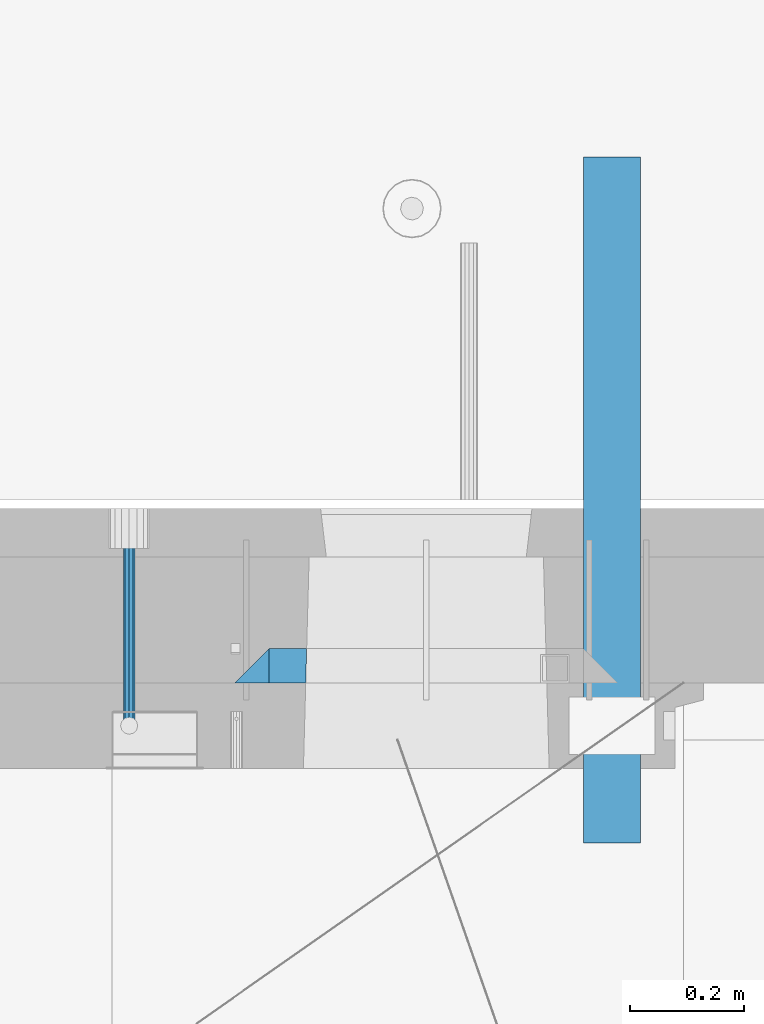
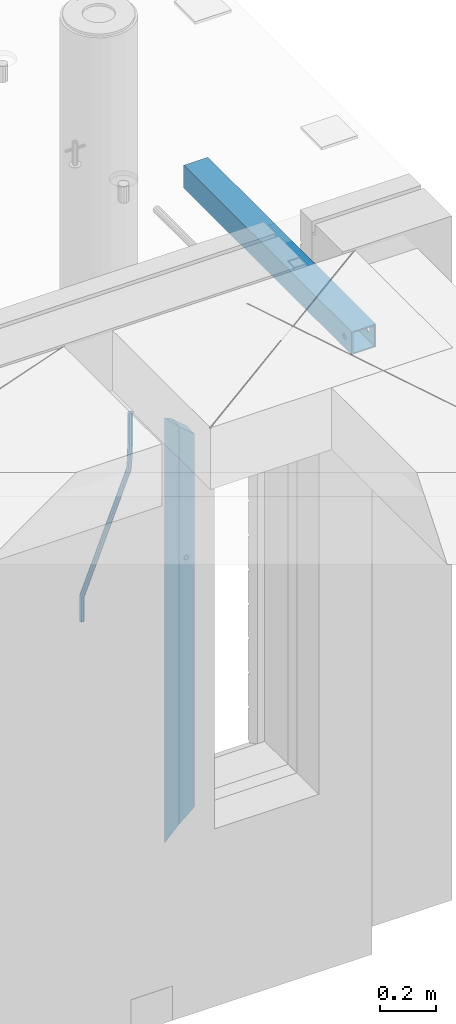
# One storey, part 114 of 309: 4 beams, 3 elements without a shape of their own.
"""IFC2X3 building model written with IfcOpenShell, lengths in millimetres."""

from ifc_helpers import new_model, si_unit, frame, origin_with_axes, place, context, subcontext, project, spatial, faceted_brep, material, type_object, element, aggregate, save


model = new_model("IFC2X3")

# Units and contexts
model_context = context("Model", 3, precision=1e-05, world=origin_with_axes())
body_context = subcontext(model_context, "Body", "Model", "MODEL_VIEW")
ifc_project = project(units=[si_unit("LENGTHUNIT", "METRE", prefix="MILLI"), si_unit("AREAUNIT", "SQUARE_METRE"), si_unit("VOLUMEUNIT", "CUBIC_METRE"), si_unit("MASSUNIT", "GRAM", prefix="KILO"), si_unit("TIMEUNIT", "SECOND"), si_unit("PLANEANGLEUNIT", "RADIAN"), si_unit("SOLIDANGLEUNIT", "STERADIAN"), si_unit("THERMODYNAMICTEMPERATUREUNIT", "DEGREE_CELSIUS"), si_unit("LUMINOUSINTENSITYUNIT", "LUMEN")], contexts=[model_context])

# Site, building, storey
site_placement = place(None, origin_with_axes())
site = spatial("IfcSite", under=ifc_project, at=site_placement, CompositionType="ELEMENT")
building_placement = place(site_placement, origin_with_axes())
building = spatial("IfcBuilding", under=site, at=building_placement, CompositionType="ELEMENT")
storey_placement = place(building_placement, origin_with_axes())
storey = spatial("IfcBuildingStorey", under=building, at=storey_placement, Name="7", CompositionType="ELEMENT", Elevation=0.0)

# Assembly, beam
assembly_1_placement = place(storey_placement, origin_with_axes())
assembly_1 = element("IfcElementAssembly", 1, at=assembly_1_placement, inside=storey, AssemblyPlace="NOTDEFINED", PredefinedType="REINFORCEMENT_UNIT")
ifc_material_1 = material()
beam_type_1 = type_object("IfcBeamType", Name="D20", PredefinedType="NOTDEFINED")
beam_1_placement = place(assembly_1_placement, frame((33890.0000001015, 20504.9951872346, 102407.5), z_axis=(0.000415599999849905, 0.999999913638203, 4.76000000899737e-07), x_axis=(0.0, 0.0, -1.0)))
beam_1 = element("IfcBeam", 2, at=beam_1_placement, type_object=beam_type_1, material=ifc_material_1, Name="JM20", ObjectType="D20", context=body_context, shape_type="Brep", body=[
    faceted_brep([(-0.00060564729210455, -9.99999998165731, 0.0), (-0.000428079845733009, -7.07106779890455, -7.07106781186667), (119.575515501536, -7.07830994756296, -7.07106481604933), (119.575337932896, -10.0072421307195, -3.43332612828817e-06), (0.0, 0.0, -10.0), (119.575943836026, -0.00724214867295814, -9.99999700418266), (0.00042843479604926, 7.07106779888636, -7.07106781186303), (119.57637202373, 7.06382565022977, -7.07106481604933), (0.00060564729210455, 9.99999998166459, 3.63797880709171e-12), (119.576549238118, 9.99275783300072, 2.99581552098971e-06), (0.000428079845733009, 7.07106779890819, 7.07106781186667), (119.576371669405, 7.06382565024978, 7.07107080768037), (0.0, 0.0, 10.0), (119.57594333493, -0.00724214864203532, 10.0000029958155), (-0.000428434810601175, -7.07106779888272, 7.07106781186667), (119.575515147211, -7.07830994754295, 7.07107080768037), (123.00654325854, -7.07836650239551, -6.96786008391246), (122.581588830741, -10.007295666459, 0.0904344953341933), (123.182419066041, -0.00729994480025198, -9.89151006310021), (123.006190977103, 7.06376911688858, -6.96788735351402), (122.581091016109, 9.99270432680532, 0.0903895128230943), (122.156136974867, 7.06377516229986, 7.14867767459873), (121.980261167351, -0.00729139528993983, 10.0723276537792), (122.156489256289, -7.07836045697513, 7.14870494419847), (237.077376207715, -7.07551629289992, -0.0988779924864502), (236.652422053201, -10.0044409119728, 6.95941204931296), (237.253252288647, -0.0044516184279928, -3.02253250974718), (237.077024472936, 7.06661932641327, -0.0989143382521434), (236.651924624995, 9.99555908263574, 6.95936064834314), (236.226970470365, 7.06663446442326, 14.0176506898479), (236.051094389448, -0.0044302100486675, 16.9413052071086), (236.227322205144, -7.07550115488812, 14.0176870356117), (256.715938387759, -7.07353516174771, 4.66794781703175), (253.858321224223, -10.0027051854922, 11.1357628166734), (257.898622435067, -0.00236892073007766, 1.98867362452802), (256.713573090979, 7.0686002544353, 4.66742272414376), (253.85497618909, 9.99729452004976, 11.1350202234971), (250.997359025234, 7.06812449537756, 17.6028352234607), (249.814674977912, -0.00304174564189452, 20.2821094159572), (250.999724322028, -7.07401092080545, 17.6033603163596), (1009.84102825288, -6.93521658215468, 337.477148757798), (1006.98341108896, -9.86438660663771, 343.944963757851), (1011.02371230032, 0.135949658781101, 334.7978745651), (1009.83866295629, 7.20691883402651, 337.476623664521), (1006.98006605446, 10.1356130998429, 343.944221163818), (1004.12244889054, 7.2064430753635, 350.412036163872), (1002.9397648431, 0.135276834424076, 353.091310356571), (1004.12481418712, -6.93569234081951, 350.412561257146), (1010.86335274603, -6.9350288225487, 337.928918327354), (1009.37086865908, -9.86394812736762, 344.999991477531), (1011.48104818776, 0.136033652863262, 334.999973251377), (1010.86211737194, 7.20710680115553, 337.928892551665), (1009.36912157628, 10.1360518725905, 344.9999550252), (1007.87663748935, 7.2071325677698, 352.071028175378), (1007.2589420476, 0.13607009235966, 354.999973251352), (1007.87787286344, -6.93500305593261, 352.071053951067), (1011.98104820926, -6.93502881915083, 337.92891832735), (1011.98104821818, -9.86394811943501, 344.999991477524), (1011.98104818776, 0.136033654382118, 334.999973251375), (1011.98104816627, 7.20710680455704, 337.928892551661), (1011.98104815738, 10.1360518805304, 344.999955025194), (1011.98104816629, 7.20713258024625, 352.071028175369), (1011.98104818778, 0.136070106711486, 354.999973251342), (1011.98104820927, -6.9350030434598, 352.071053951058), (1117.50000002154, -6.93502849844299, 337.928918327156), (1117.50000003044, -9.86394779872717, 344.999991477331), (1117.50000000004, 0.136033975091777, 334.999973251181), (1117.49999997855, 7.20710712526488, 337.928892551467), (1117.49999996964, 10.1360522012383, 344.999955025), (1117.49999997857, 7.20713290095409, 352.071028175174), (1117.50000000006, 0.136070427419327, 354.999973251148), (1117.50000002155, -6.93500272275196, 352.071053950864)], [[[0, 1, 2, 3]], [[1, 4, 5, 2]], [[4, 6, 7, 5]], [[6, 8, 9, 7]], [[8, 10, 11, 9]], [[10, 12, 13, 11]], [[12, 14, 15, 13]], [[14, 0, 3, 15]], [[14, 12, 10, 8, 6, 4, 1, 0]], [[3, 2, 16, 17]], [[2, 5, 18, 16]], [[5, 7, 19, 18]], [[7, 9, 20, 19]], [[9, 11, 21, 20]], [[11, 13, 22, 21]], [[13, 15, 23, 22]], [[15, 3, 17, 23]], [[17, 16, 24, 25]], [[16, 18, 26, 24]], [[18, 19, 27, 26]], [[19, 20, 28, 27]], [[20, 21, 29, 28]], [[21, 22, 30, 29]], [[22, 23, 31, 30]], [[23, 17, 25, 31]], [[25, 24, 32, 33]], [[24, 26, 34, 32]], [[26, 27, 35, 34]], [[27, 28, 36, 35]], [[28, 29, 37, 36]], [[29, 30, 38, 37]], [[30, 31, 39, 38]], [[31, 25, 33, 39]], [[33, 32, 40, 41]], [[32, 34, 42, 40]], [[34, 35, 43, 42]], [[35, 36, 44, 43]], [[36, 37, 45, 44]], [[37, 38, 46, 45]], [[38, 39, 47, 46]], [[39, 33, 41, 47]], [[41, 40, 48, 49]], [[40, 42, 50, 48]], [[42, 43, 51, 50]], [[43, 44, 52, 51]], [[44, 45, 53, 52]], [[45, 46, 54, 53]], [[46, 47, 55, 54]], [[47, 41, 49, 55]], [[49, 48, 56, 57]], [[48, 50, 58, 56]], [[50, 51, 59, 58]], [[51, 52, 60, 59]], [[52, 53, 61, 60]], [[53, 54, 62, 61]], [[54, 55, 63, 62]], [[55, 49, 57, 63]], [[57, 56, 64, 65]], [[56, 58, 66, 64]], [[58, 59, 67, 66]], [[59, 60, 68, 67]], [[60, 61, 69, 68]], [[61, 62, 70, 69]], [[62, 63, 71, 70]], [[63, 57, 65, 71]], [[66, 67, 68, 69, 70, 71, 65, 64]]]),
])

# Assemblies, beam
assembly_2_placement = place(storey_placement, origin_with_axes())
assembly_2 = element("IfcElementAssembly", 3, at=assembly_2_placement, inside=storey, AssemblyPlace="NOTDEFINED", PredefinedType="REINFORCEMENT_UNIT")
assembly_3_placement = place(assembly_2_placement, origin_with_axes())
assembly_3 = element("IfcElementAssembly", 4, at=assembly_3_placement, AssemblyPlace="NOTDEFINED", PredefinedType="NOTDEFINED")
aggregate(assembly_2, [assembly_3])
ifc_material_2 = material(Name="Undefined/350")
beam_type_2 = type_object("IfcBeamType", Name="100X100X5", PredefinedType="NOTDEFINED")
beam_2_placement = place(assembly_3_placement, frame((34735.0001432011, 21500.0034426031, 102555.0), z_axis=(0.0, 0.0, 1.0), x_axis=(-2.2242999997242e-05, -0.999999999752625, 0.0)))
beam_2 = element("IfcBeam", 5, at=beam_2_placement, type_object=beam_type_2, material=ifc_material_2, ObjectType="100X100X5", context=body_context, shape_type="Brep", body=[
    faceted_brep([(1143.75108023171, 44.9999999999982, -10.8253175473074), (1143.75107855316, 50.0255964196231, -10.8253175473074), (1139.17576100585, 50.0255948914664, -6.25), (1139.1757626844, 44.9999999999982, -6.25), (1150.00108023171, 44.9999999999982, -12.5), (1150.00107855316, 50.0255985071226, -12.5), (1156.2510802317, 44.9999999999982, -10.8253175473074), (1156.25107855315, 50.0256005946221, -10.8253175473074), (1160.82639777901, 44.9999999999982, -6.25), (1160.82639610046, 50.0256021227788, -6.25), (1162.50108023171, 44.9999999999982, 0.0), (1162.50107855316, 50.0256026821226, 0.0), (1160.82639777901, 44.9999999999982, 6.25), (1160.82639610046, 50.0256021227788, 6.25), (1156.2510802317, 44.9999999999982, 10.8253175473074), (1156.25107855315, 50.0256005946221, 10.8253175473074), (1150.00108023171, 44.9999999999982, 12.5), (1150.00107855316, 50.0255985071226, 12.5), (1143.75108023171, 44.9999999999982, 10.8253175473074), (1143.75107855316, 50.0255964196231, 10.8253175473074), (1139.1757626844, 44.9999999999982, 6.25), (1139.17576100585, 50.0255948914664, 6.25), (1137.5010802317, 44.9999999999982, 0.0), (1137.50107855316, 50.0255943321226, 0.0), (1143.75111195316, -49.9744035792783, -10.8253175473074), (1143.75111029171, -44.9999999999991, -10.8253175473074), (1139.1757927444, -44.9999999999991, -6.25), (1139.17579440585, -49.9744051074349, -6.25), (1150.00111195316, -49.9744014917787, -12.5), (1150.00111029171, -44.9999999999991, -12.5), (1156.25111195316, -49.9743994042774, -10.8253175473074), (1156.25111029171, -44.9999999999991, -10.8253175473074), (1160.82642950046, -49.9743978761207, -6.25), (1160.82642783901, -44.9999999999991, -6.25), (1162.50111195316, -49.9743973167779, 0.0), (1162.50111029171, -44.9999999999991, 0.0), (1160.82642950046, -49.9743978761207, 6.25), (1160.82642783901, -44.9999999999991, 6.25), (1156.25111195316, -49.9743994042774, 10.8253175473074), (1156.25111029171, -44.9999999999991, 10.8253175473074), (1150.00111195316, -49.9744014917787, 12.5), (1150.00111029171, -44.9999999999991, 12.5), (1143.75111195316, -49.9744035792783, 10.8253175473074), (1143.75111029171, -44.9999999999991, 10.8253175473074), (1139.17579440585, -49.9744051074349, 6.25), (1139.1757927444, -44.9999999999991, 6.25), (1137.50111195316, -49.9744056667778, 0.0), (1137.50111029171, -44.9999999999991, 0.0), (1.81898940354586e-12, -50.0000000000009, -50.0), (1.81898940354586e-12, 49.9999999999991, -50.0), (1200.00449189278, 49.9999999999982, -50.0), (1200.00449189278, -50.0000000000009, -50.0), (1.81898940354586e-12, 49.9999999999991, 50.0), (1.81898940354586e-12, -50.0000000000009, 50.0), (1200.00449189278, -50.0000000000009, 50.0), (1200.00449189278, 49.9999999999982, 50.0), (0.0, 44.9999999999991, 45.0), (1.81898940354586e-12, -45.0000000000009, 45.0), (1.81898940354586e-12, -45.0000000000009, -45.0), (0.0, 44.9999999999991, -45.0), (1200.00449189278, 44.9999999999982, -45.0), (1200.00449189278, 44.9999999999982, 45.0), (1200.00449189278, -45.0000000000009, 45.0), (1200.00449189278, -45.0000000000009, -45.0)], [[[0, 1, 2, 3]], [[4, 5, 1, 0]], [[6, 7, 5, 4]], [[8, 9, 7, 6]], [[10, 11, 9, 8]], [[12, 13, 11, 10]], [[14, 15, 13, 12]], [[16, 17, 15, 14]], [[18, 19, 17, 16]], [[20, 21, 19, 18]], [[22, 23, 21, 20]], [[3, 2, 23, 22]], [[24, 25, 26, 27]], [[28, 29, 25, 24]], [[30, 31, 29, 28]], [[32, 33, 31, 30]], [[34, 35, 33, 32]], [[36, 37, 35, 34]], [[38, 39, 37, 36]], [[40, 41, 39, 38]], [[42, 43, 41, 40]], [[44, 45, 43, 42]], [[46, 47, 45, 44]], [[27, 26, 47, 46]], [[48, 49, 50, 51]], [[52, 53, 54, 55]], [[49, 52, 55, 50], [15, 17, 19, 21, 23, 2, 1, 5, 7, 9, 11, 13]], [[48, 53, 52, 49], [56, 57, 58, 59]], [[56, 59, 60, 61], [6, 4, 0, 3, 22, 20, 18, 16, 14, 12, 10, 8]], [[57, 56, 61, 62]], [[58, 57, 62, 63], [39, 41, 43, 45, 47, 26, 25, 29, 31, 33, 35, 37]], [[59, 58, 63, 60]], [[54, 51, 50, 55], [62, 61, 60, 63]], [[53, 48, 51, 54], [30, 28, 24, 27, 46, 44, 42, 40, 38, 36, 34, 32]]]),
])
aggregate(assembly_3, [beam_2])

# Beam
ifc_material_3 = material(Name="CONCRETE/C25/30")
beam_type_3 = type_object("IfcBeamType", PredefinedType="NOTDEFINED")
beam_3_placement = place(assembly_1_placement, frame((34105.0055090716, 20609.9951872276, 102275.0), z_axis=(1.0, 0.0, 0.0), x_axis=(0.0, 0.0, -1.0)))
beam_3 = element("IfcBeam", 6, at=beam_3_placement, type_object=beam_type_3, material=ifc_material_3, Name="SK", context=body_context, shape_type="Brep", body=[
    faceted_brep([(60.0000000000073, 30.0, 30.0), (0.0, -30.0, -30.0), (60.0000000000073, -30.0, 30.0), (1795.00000000001, 30.0, 30.0), (1855.0, -30.0, -30.0), (1795.00000000001, -30.0, 30.0)], [[[0, 1, 2]], [[3, 4, 1, 0]], [[4, 5, 2, 1]], [[5, 3, 0, 2]], [[5, 4, 3]]]),
])

beam_type_4 = type_object("IfcBeamType", PredefinedType="NOTDEFINED")
beam_4_placement = place(assembly_1_placement, frame((34170.0055090716, 20609.9951872276, 102215.0), z_axis=(1.0, 0.0, 0.0), x_axis=(0.0, 0.0, -1.0)))
beam_4 = element("IfcBeam", 7, at=beam_4_placement, type_object=beam_type_4, material=ifc_material_3, Name="SK", context=body_context, shape_type="Brep", body=[
    faceted_brep([(0.0, -30.0, -35.0), (54.9034748914273, -30.0, 29.0540540540533), (56.2934362811066, 30.0, 30.6756756756768), (0.0, 30.0, -35.0), (1678.70656371891, 30.0, 30.6756756756768), (1735.0, 30.0, -35.0), (1735.0, -30.0, -35.0), (1680.09652510857, -30.0, 29.0540540540533)], [[[0, 1, 2, 3]], [[3, 2, 4, 5]], [[5, 6, 0, 3]], [[1, 0, 6, 7]], [[2, 1, 7, 4]], [[6, 5, 4, 7]]]),
])

aggregate(assembly_1, [beam_1, beam_4, beam_3])

save(model, "model.ifc")
